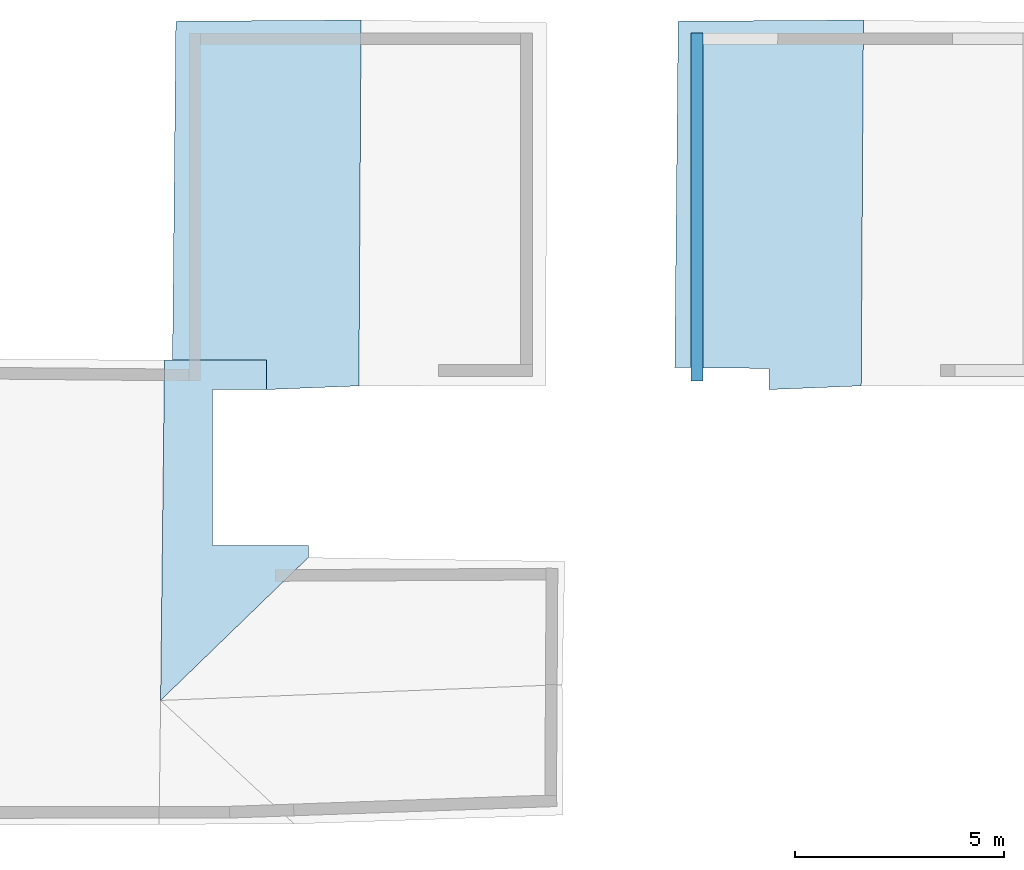
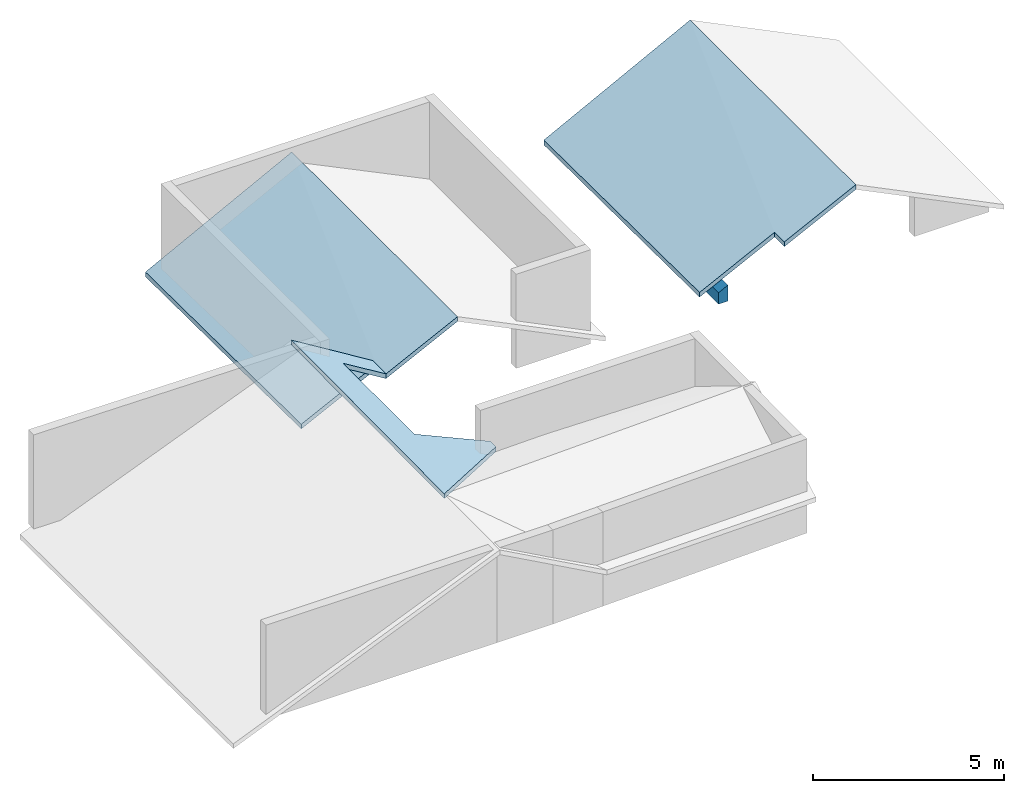
# One storey, part 2 of 2: 5 slabs, 1 wall.
"""IFC4 building model written with IfcOpenShell, lengths in metres."""

from ifc_helpers import new_model, entity, si_unit, converted_unit, frame, frame_2d, origin_with_axes, place, context, subcontext, project, spatial, polygons, element, save


model = new_model("IFC4")

# Units and contexts
model_context = context("Model", 3, precision=1e-05, world=origin_with_axes())
plan_context = context("Plan", 2, precision=1e-05, world=frame_2d((0.0, 0.0, 0.0), x_axis=(1.0, 0.0, 0.0)))
body_context = subcontext(model_context, "Body", "Model", "MODEL_VIEW")
ifc_project = project(units=[converted_unit("PLANEANGLEUNIT", "degree", entity("IfcReal", 0.0174532925199433), si_unit("PLANEANGLEUNIT", "RADIAN"), dimensions=[0, 0, 0, 0, 0, 0, 0]), si_unit("AREAUNIT", "SQUARE_METRE"), si_unit("VOLUMEUNIT", "CUBIC_METRE"), si_unit("LENGTHUNIT", "METRE")], contexts=[model_context, plan_context])

# Site, building, storey
site_placement = place(None, origin_with_axes())
site = spatial("IfcSite", under=ifc_project, at=site_placement)
building_placement = place(site_placement, origin_with_axes())
building = spatial("IfcBuilding", under=site, at=building_placement, Name="Building")
storey_placement = place(building_placement, frame((0.0, 0.0, 3.0), z_axis=(0.0, 0.0, 1.0), x_axis=(1.0, 0.0, 0.0)))
storey = spatial("IfcBuildingStorey", under=building, at=storey_placement, Name="Dachgeschoss")

# Slabs
slab_1_placement = place(storey_placement, frame((26.8203887939453, 9.78442668914795, -2.06702888011932), z_axis=(0.0, 0.0, 1.0), x_axis=(1.0, 0.0, 0.0)))
element("IfcSlab", 1, at=slab_1_placement, inside=storey, Name="dach_wohnen_w", PredefinedType="ROOF", context=body_context, shape_type="Tessellation", body=[
    polygons([(-18.3055820465088, -6.04181098937988, 5.09152317047119), (-14.7738656997681, -2.62468528747559, 3.28549098968506), (-18.2124099731445, 2.09556102752686, 5.02737331390381), (-17.0658378601074, 1.3901504278183, 4.31534337997437), (-15.7722063064575, 1.39000952243805, 3.52441787719727), (-15.7722063064575, 2.09556126594543, 3.52441787719727), (-14.7738656997681, -2.33506321907043, 3.28549098968506), (-17.0658378601074, -2.33499145507813, 4.31534337997437), (-18.2124099731445, 2.09556102752686, 4.87737321853638), (-18.3055820465088, -6.04181098937988, 4.94152307510376), (-14.7738656997681, -2.62468528747559, 3.13549089431763), (-15.7722063064575, 2.09556126594543, 3.37441778182983), (-17.0658378601074, 1.3901504278183, 4.16534328460693), (-15.7722063064575, 1.39000952243805, 3.37441778182983), (-14.7738656997681, -2.33506321907043, 3.13549089431763), (-17.0658378601074, -2.33499145507813, 4.16534328460693)], [[[1, 3, 8]], [[16, 13, 9]], [[7, 8, 16, 15]], [[5, 6, 12, 14]], [[6, 3, 9, 12]], [[3, 10, 9]], [[4, 16, 8]], [[2, 7, 15, 11]], [[4, 5, 14, 13]], [[1, 2, 11, 10]], [[3, 6, 4]], [[6, 5, 4]], [[7, 2, 8]], [[2, 1, 8]], [[3, 4, 8]], [[10, 11, 16]], [[11, 15, 16]], [[14, 12, 13]], [[12, 9, 13]], [[10, 16, 9]], [[3, 1, 10]], [[4, 13, 16]]]),
])
for number, where, z_axis, x_axis, name in (
    (2, (11.5073595046997, 19.0338859558105, -0.612094879150391), (0.0, 0.0, 1.0), (1.0, 0.0, 0.0), "dach_so"),
    (3, (11.5073595046997, 19.0338859558105, -0.612094879150391), (0.0, 0.0, 1.0), (1.0, 0.0, 0.0), "dach_so"),
):
    element("IfcSlab", number, at=place(storey_placement, frame(where, z_axis=z_axis, x_axis=x_axis)), inside=storey, Name=name, PredefinedType="ROOF", context=body_context, shape_type="Tessellation", body=[
        polygons([(-2.97228264808655, -7.43174934387207, 0.821340084075928), (1.74949443340302, -7.77036571502686, 3.06659126281738), (-2.62752819061279, 0.947076737880707, 0.736433267593384), (1.80188846588135, 0.977355897426605, 2.99584007263184), (-0.459177732467651, -7.85944890975952, 2.06948375701904), (-2.70927309989929, -7.33231735229492, 0.930184245109558), (-0.459176629781723, -7.35307836532593, 2.06948399543762), (1.74949443340302, -7.77036571502686, 2.91659116744995), (1.80188846588135, 0.977355897426605, 2.8458399772644), (-2.62752819061279, 0.947076737880707, 0.586433291435242), (-2.70927309989929, -7.33231735229492, 0.780184268951416), (-0.459177732467651, -7.85944890975952, 1.9194837808609), (-0.459176629781723, -7.35307836532593, 1.91948401927948)], [[[2, 5, 7]], [[9, 10, 13]], [[6, 7, 13, 11]], [[4, 3, 10, 9]], [[3, 6, 11, 10]], [[5, 2, 8, 12]], [[7, 5, 12, 13]], [[2, 4, 9, 8]], [[7, 6, 3]], [[3, 4, 7]], [[4, 2, 7]], [[10, 11, 13]], [[13, 12, 8]], [[8, 9, 13]]]),
    ])
slab_2_placement = place(storey_placement, frame((26.8203887939453, 9.78442668914795, -2.06702888011932), z_axis=(0.0, 0.0, 1.0), x_axis=(1.0, 0.0, 0.0)))
element("IfcSlab", 4, at=slab_2_placement, inside=storey, Name="dach_wohnen_w", PredefinedType="ROOF", context=body_context, shape_type="Tessellation", body=[
    polygons([(-18.3055820465088, -6.04181098937988, 5.09152317047119), (-14.7738656997681, -2.62468528747559, 3.28549098968506), (-18.2124099731445, 2.09556102752686, 5.02737331390381), (-17.0658378601074, 1.3901504278183, 4.31534337997437), (-15.7722063064575, 1.39000952243805, 3.52441787719727), (-15.7722063064575, 2.09556126594543, 3.52441787719727), (-14.7738656997681, -2.33506321907043, 3.28549098968506), (-17.0658378601074, -2.33499145507813, 4.31534337997437), (-18.2124099731445, 2.09556102752686, 4.87737321853638), (-18.3055820465088, -6.04181098937988, 4.94152307510376), (-14.7738656997681, -2.62468528747559, 3.13549089431763), (-15.7722063064575, 2.09556126594543, 3.37441778182983), (-17.0658378601074, 1.3901504278183, 4.16534328460693), (-15.7722063064575, 1.39000952243805, 3.37441778182983), (-14.7738656997681, -2.33506321907043, 3.13549089431763), (-17.0658378601074, -2.33499145507813, 4.16534328460693)], [[[1, 3, 8]], [[16, 13, 9]], [[7, 8, 16, 15]], [[5, 6, 12, 14]], [[6, 3, 9, 12]], [[3, 10, 9]], [[4, 16, 8]], [[2, 7, 15, 11]], [[4, 5, 14, 13]], [[1, 2, 11, 10]], [[3, 6, 4]], [[6, 5, 4]], [[7, 2, 8]], [[2, 1, 8]], [[3, 4, 8]], [[10, 11, 16]], [[11, 15, 16]], [[14, 12, 13]], [[12, 9, 13]], [[10, 16, 9]], [[3, 1, 10]], [[4, 13, 16]]]),
])
slab_3_placement = place(storey_placement, frame((23.5172271728516, 19.0338859558105, -0.612094879150391), z_axis=(0.0, 0.0, 1.0), x_axis=(1.0, 0.0, 0.0)))
element("IfcSlab", 5, at=slab_3_placement, inside=storey, Name="dach_so.001", PredefinedType="ROOF", context=body_context, shape_type="Tessellation", body=[
    polygons([(1.74949443340302, -7.77036571502686, 3.06659126281738), (-0.459176629781723, -7.35307836532593, 2.06948399543762), (-0.459177732467651, -7.85944890975952, 2.06948375701904), (1.80188846588135, 0.977355897426605, 2.8458399772644), (-0.459176629781723, -7.35307836532593, 1.91948401927948), (-2.62752819061279, 0.947076737880707, 0.586433291435242), (-2.70927309989929, -7.33231735229492, 0.930184245109558), (-2.70927309989929, -7.33231735229492, 0.780184268951416), (1.80188846588135, 0.977355897426605, 2.99584007263184), (-2.62752819061279, 0.947076737880707, 0.736433267593384), (-0.459177732467651, -7.85944890975952, 1.9194837808609), (1.74949443340302, -7.77036571502686, 2.91659116744995)], [[[2, 3, 1]], [[3, 11, 12, 1]], [[6, 10, 9, 4]], [[10, 2, 9]], [[1, 12, 4, 9]], [[8, 7, 10, 6]], [[6, 5, 8]], [[9, 2, 1]], [[12, 11, 5]], [[4, 12, 5]], [[2, 5, 11, 3]], [[8, 5, 2, 7]], [[10, 7, 2]], [[6, 4, 5]]]),
])

# Wall
wall_placement = place(storey_placement, frame((21.1986961364746, 19.7012138366699, -2.38418579101562e-07), z_axis=(0.0, 0.0, 1.0), x_axis=(-1.62920684942947e-07, -1.0, 0.0)))
element("IfcWall", 6, at=wall_placement, inside=storey, Name="Wall.019", PredefinedType="ELEMENTEDWALL", context=body_context, shape_type="Tessellation", body=[
    polygons([(0.0, 0.0, 0.0), (0.0, 0.280000001192093, 0.0), (8.31982421875, 0.280000001192093, 0.0), (8.31982421875, 0.0, 0.0), (0.0, 0.0, 0.139650017023087), (8.00583457946777, 0.280000001192093, 0.507708966732025), (8.31982421875, 0.0, 0.367414385080338), (8.31982421875, 0.280000001192093, 0.509175777435303), (7.55927385398536e-06, 0.0, 0.139650225639343), (8.00325012207031, 0.0, 0.365935534238815), (0.0, 0.152444392442703, 0.217439025640488), (0.0, 0.280000001192093, 0.282527834177017), (8.00578308105469, 0.280000001192093, 0.507707536220551), (8.00583457946777, 0.280000001192093, 0.507708966732025), (8.00543594360352, 0.236810266971588, 0.485840559005737), (8.90236151462886e-06, 3.11355563553661e-07, 0.139650419354439), (8.00572299957275, 0.27999609708786, 0.507703840732574), (8.00497913360596, 0.187314450740814, 0.460779160261154)], [[[7, 4, 3, 8]], [[5, 1, 4, 7, 10, 9]], [[2, 1, 5, 11, 12]], [[4, 1, 2, 3]], [[3, 2, 12, 13, 6, 14, 8]]]),
    polygons([(0.0, 0.0, 0.0), (0.0, 0.280000001192093, 0.0), (8.31982421875, 0.280000001192093, 0.0), (8.31982421875, 0.0, 0.0), (0.0, 0.0, 0.139650017023087), (8.00583457946777, 0.280000001192093, 0.507708966732025), (8.31982421875, 0.0, 0.367414385080338), (8.31982421875, 0.280000001192093, 0.509175777435303), (7.55927385398536e-06, 0.0, 0.139650225639343), (8.00325012207031, 0.0, 0.365935534238815), (0.0, 0.152444392442703, 0.217439025640488), (0.0, 0.280000001192093, 0.282527834177017), (8.00578308105469, 0.280000001192093, 0.507707536220551), (8.00583457946777, 0.280000001192093, 0.507708966732025), (8.00543594360352, 0.236810266971588, 0.485840559005737), (8.90236151462886e-06, 3.11355563553661e-07, 0.139650419354439), (8.00572299957275, 0.27999609708786, 0.507703840732574), (8.00497913360596, 0.187314450740814, 0.460779160261154)], [[[6, 15, 14]], [[6, 13, 17]], [[11, 5, 9, 16]], [[10, 18, 11]], [[18, 10, 7, 8, 14, 15]], [[17, 18, 15]], [[15, 6, 17]], [[13, 12, 11]], [[16, 9, 10]], [[13, 11, 17]], [[11, 16, 10]], [[17, 11, 18]]]),
])

save(model, "model.ifc")
